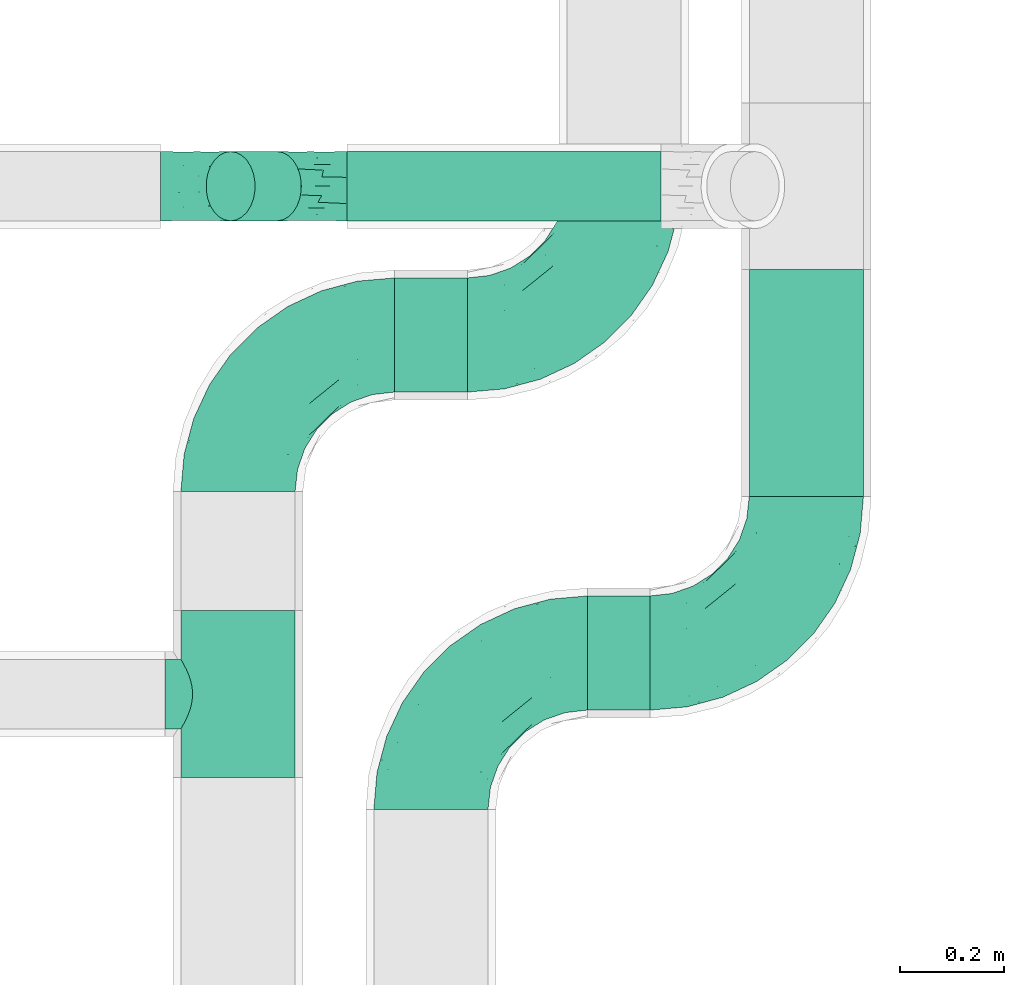
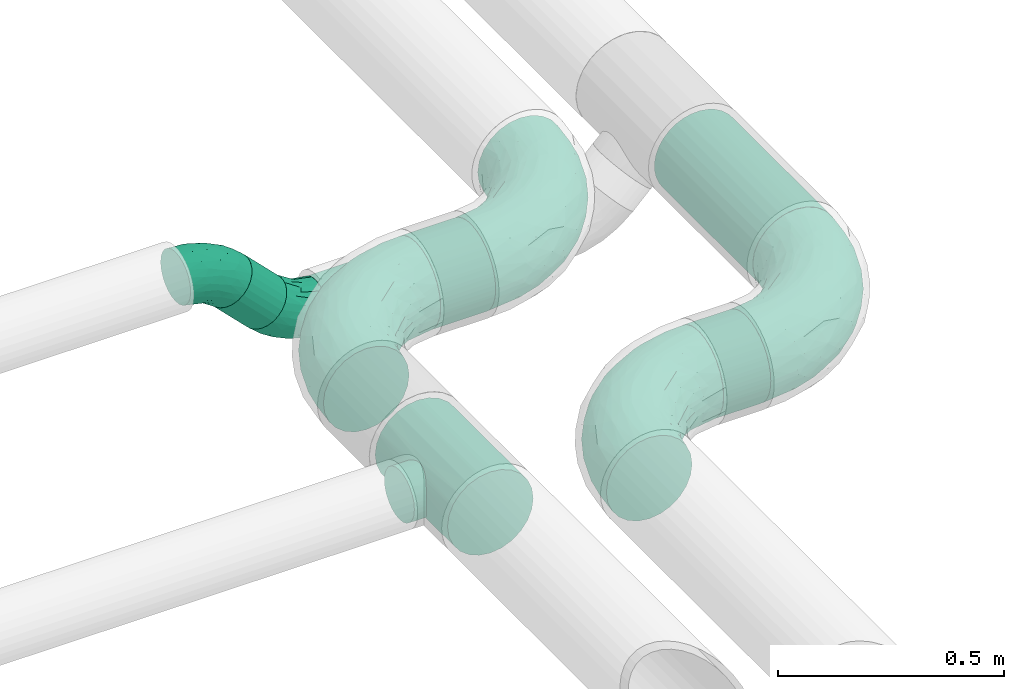
# One storey, part 73 of 93: 7 flow fittings, 5 flow segments.
"""IFC2X3 building model written with IfcOpenShell, lengths in millimetres."""

from ifc_helpers import new_model, entity, si_unit, converted_unit, derived_unit, direction, frame, origin, origin_2d_with_axis, place, context, subcontext, project, spatial, circle, extrude, faceted_brep, source, transform, mapped, material, type_object, type_shapes, element, save


model = new_model("IFC2X3")

# Units and contexts
model_context = context("Model", 3, precision=0.01, world=origin(), true_north=direction((6.12303176911189e-17, 1.0)))
body_context = subcontext(model_context, "Body", "Model", "MODEL_VIEW")
ifc_project = project(units=[si_unit("LENGTHUNIT", "METRE", prefix="MILLI"), si_unit("AREAUNIT", "SQUARE_METRE"), si_unit("VOLUMEUNIT", "CUBIC_METRE"), converted_unit("PLANEANGLEUNIT", "DEGREE", entity("IfcRatioMeasure", 0.0174532925199433), si_unit("PLANEANGLEUNIT", "RADIAN"), dimensions=[0, 0, 0, 0, 0, 0, 0]), si_unit("MASSUNIT", "GRAM", prefix="KILO"), derived_unit("MASSDENSITYUNIT", [(si_unit("MASSUNIT", "GRAM", prefix="KILO"), 1), (si_unit("LENGTHUNIT", "METRE"), -3)]), derived_unit("MOMENTOFINERTIAUNIT", [(si_unit("LENGTHUNIT", "METRE"), 4)]), si_unit("TIMEUNIT", "SECOND"), si_unit("FREQUENCYUNIT", "HERTZ"), si_unit("THERMODYNAMICTEMPERATUREUNIT", "DEGREE_CELSIUS"), derived_unit("THERMALTRANSMITTANCEUNIT", [(si_unit("MASSUNIT", "GRAM", prefix="KILO"), 1), (si_unit("THERMODYNAMICTEMPERATUREUNIT", "KELVIN"), -1), (si_unit("TIMEUNIT", "SECOND"), -3)]), derived_unit("VOLUMETRICFLOWRATEUNIT", [(si_unit("LENGTHUNIT", "METRE"), 3), (si_unit("TIMEUNIT", "SECOND"), -1)]), derived_unit("MASSFLOWRATEUNIT", [(si_unit("MASSUNIT", "GRAM", prefix="KILO"), 1), (si_unit("TIMEUNIT", "SECOND"), -1)]), derived_unit("ROTATIONALFREQUENCYUNIT", [(si_unit("TIMEUNIT", "SECOND"), -1)]), si_unit("ELECTRICCURRENTUNIT", "AMPERE"), si_unit("ELECTRICVOLTAGEUNIT", "VOLT"), si_unit("POWERUNIT", "WATT"), si_unit("FORCEUNIT", "NEWTON", prefix="KILO"), si_unit("ILLUMINANCEUNIT", "LUX"), si_unit("LUMINOUSFLUXUNIT", "LUMEN"), si_unit("LUMINOUSINTENSITYUNIT", "CANDELA"), derived_unit("USERDEFINED", [(si_unit("MASSUNIT", "GRAM", prefix="KILO"), -1), (si_unit("LENGTHUNIT", "METRE"), -2), (si_unit("TIMEUNIT", "SECOND"), 3), (si_unit("LUMINOUSFLUXUNIT", "LUMEN"), 1)]), derived_unit("LINEARVELOCITYUNIT", [(si_unit("LENGTHUNIT", "METRE"), 1), (si_unit("TIMEUNIT", "SECOND"), -1)]), si_unit("PRESSUREUNIT", "PASCAL"), derived_unit("USERDEFINED", [(si_unit("LENGTHUNIT", "METRE"), -2), (si_unit("MASSUNIT", "GRAM", prefix="KILO"), 1), (si_unit("TIMEUNIT", "SECOND"), -2)]), derived_unit("LINEARFORCEUNIT", [(si_unit("MASSUNIT", "GRAM", prefix="KILO"), 1), (si_unit("LENGTHUNIT", "METRE"), 1), (si_unit("TIMEUNIT", "SECOND"), -2), (si_unit("LENGTHUNIT", "METRE"), -1)]), derived_unit("PLANARFORCEUNIT", [(si_unit("MASSUNIT", "GRAM", prefix="KILO"), 1), (si_unit("LENGTHUNIT", "METRE"), 1), (si_unit("TIMEUNIT", "SECOND"), -2), (si_unit("LENGTHUNIT", "METRE"), -2)])], contexts=[model_context])

# Site, building, storey
site_placement = place(None, origin())
site = spatial("IfcSite", under=ifc_project, at=site_placement, CompositionType="ELEMENT")
building_placement = place(site_placement, origin())
building = spatial("IfcBuilding", under=site, at=building_placement, CompositionType="ELEMENT")
storey_placement = place(building_placement, frame((0.0, 0.0, -4200.0)))
storey = spatial("IfcBuildingStorey", under=building, at=storey_placement, CompositionType="ELEMENT", Elevation=-4200.0)

# Flow segments
pipe_segment_type = type_object("IfcPipeSegmentType", PredefinedType="NOTDEFINED")
flow_segment_1_placement = place(storey_placement, frame((31009.78, 8467.66, 2688.9)))
element("IfcFlowSegment", 1, at=flow_segment_1_placement, inside=storey, type_object=pipe_segment_type, context=body_context, shape_type="SweptSolid", body=[
    extrude(circle(Radius=109.5, at=origin_2d_with_axis()), frame((0.0, 111.1, 111.1), z_axis=(1.0, 0.0, 0.0), x_axis=(0.0, -1.0, 0.0)), (0.0, 0.0, 1.0), 120.218301649666),
])
flow_segment_2_placement = place(storey_placement, frame((30639.78, 9077.66, 2688.9)))
element("IfcFlowSegment", 2, at=flow_segment_2_placement, inside=storey, type_object=pipe_segment_type, context=body_context, shape_type="SweptSolid", body=[
    extrude(circle(Radius=109.5, at=origin_2d_with_axis()), frame((0.0, 111.1, 111.1), z_axis=(1.0, 0.0, 0.0), x_axis=(0.0, -1.0, 0.0)), (0.0, 0.0, 1.0), 140.218301649687),
])
flow_segment_3_placement = place(storey_placement, frame((31318.9, 8878.76, 2688.9)))
element("IfcFlowSegment", 3, at=flow_segment_3_placement, inside=storey, type_object=pipe_segment_type, context=body_context, shape_type="SweptSolid", body=[
    extrude(circle(Radius=109.5, at=origin_2d_with_axis()), frame((111.1, 0.0, 111.1), z_axis=(0.0, 1.0, 0.0), x_axis=(1.0, 0.0, 0.0)), (0.0, 0.0, 1.0), 435.378639737443),
])
flow_segment_4_placement = place(storey_placement, frame((30548.7, 9406.04, 2531.9)))
element("IfcFlowSegment", 4, at=flow_segment_4_placement, inside=storey, type_object=pipe_segment_type, context=body_context, shape_type="SweptSolid", body=[
    extrude(circle(Radius=66.5, at=origin_2d_with_axis()), frame((0.0, 68.1, 68.1), z_axis=(1.0, 0.0, 0.0), x_axis=(0.0, 1.0, 0.0)), (0.0, 0.0, 1.0), 602.598846298237),
])
flow_segment_5_placement = place(storey_placement, frame((30277.03, 9406.04, 2607.03)))
element("IfcFlowSegment", 5, at=flow_segment_5_placement, inside=storey, type_object=pipe_segment_type, context=body_context, shape_type="SweptSolid", body=[
    extrude(circle(Radius=66.5, at=origin_2d_with_axis()), frame((137.32, 68.1, 48.62), z_axis=(-0.707106781186466, 0.0, 0.70710678118663), x_axis=(0.0, 1.0, 0.0)), (0.0, 0.0, 1.0), 125.44155877284),
])

# Flow fittings
ifc_material = material()
pipe_fitting_type_1 = type_object("IfcPipeFittingType", Name="ADSK_2", PredefinedType="NOTDEFINED", material=ifc_material)
shared_shape_1 = source(origin(), body_context, "Body", "Brep", [
    faceted_brep([(-300.0, 54.75, -94.83), (-300.0, 28.34, -105.77), (-300.0, 0.0, -109.5), (-300.0, -28.34, -105.77), (-300.0, -54.75, -94.83), (-300.0, -77.43, -77.43), (-300.0, -94.83, -54.75), (-300.0, -105.77, -28.34), (-300.0, -109.5, 0.0), (-300.0, -105.77, 28.34), (-300.0, -94.83, 54.75), (-300.0, -77.43, 77.43), (-300.0, -54.75, 94.83), (-300.0, -28.34, 105.77), (-300.0, 0.0, 109.5), (-300.0, 28.34, 105.77), (-300.0, 54.75, 94.83), (-300.0, 77.43, 77.43), (-300.0, 94.83, 54.75), (-300.0, 105.77, 28.34), (-300.0, 109.5, 0.0), (-300.0, 105.77, -28.34), (-300.0, 94.83, -54.75), (-300.0, 77.43, -77.43), (0.0, 300.0, -109.5), (-28.34, 300.0, -105.77), (-54.75, 300.0, -94.83), (-77.43, 300.0, -77.43), (-94.83, 300.0, -54.75), (-105.77, 300.0, -28.34), (-109.5, 300.0, 0.0), (-105.77, 300.0, 28.34), (-94.83, 300.0, 54.75), (-77.43, 300.0, 77.43), (-54.75, 300.0, 94.83), (-28.34, 300.0, 105.77), (0.0, 300.0, 109.5), (28.34, 300.0, 105.77), (54.75, 300.0, 94.83), (77.43, 300.0, 77.43), (94.83, 300.0, 54.75), (105.77, 300.0, 28.34), (109.5, 300.0, 0.0), (105.77, 300.0, -28.34), (94.83, 300.0, -54.75), (77.43, 300.0, -77.43), (54.75, 300.0, -94.83), (28.34, 300.0, -105.77), (-136.7, 192.11, 33.4), (-108.06, 242.04, 45.72), (-115.25, 243.91, 23.63), (-228.89, -103.28, 0.0), (-205.72, -93.9, 30.98), (-223.48, -82.05, 62.89), (82.05, 223.48, 62.89), (-220.42, -37.16, 99.17), (-129.13, -11.54, 94.5), (-142.05, 16.57, 106.73), (-36.78, -13.7, 0.0), (-12.01, 12.01, 21.92), (-70.11, -34.19, 28.86), (-251.45, -65.77, 85.04), (25.82, 74.91, 52.65), (64.71, 143.75, 51.25), (23.5, 97.93, 73.21), (-132.85, -71.12, 23.16), (-159.94, -84.8, 0.0), (-95.25, -54.64, 0.0), (-96.13, 227.29, 70.78), (-125.84, 193.4, 53.02), (-74.91, -25.82, 52.65), (-17.67, 17.67, 46.21), (-143.75, -64.71, 51.25), (34.19, 70.11, 28.86), (-36.83, 151.15, 109.47), (-72.47, 101.01, 109.48), (-16.57, 142.05, 106.73), (-230.69, 46.79, 102.89), (-151.06, 181.23, 0.0), (-193.02, 137.32, 30.03), (-245.74, 114.87, 22.86), (-217.35, 128.37, 0.0), (-257.61, 114.28, 0.0), (-206.97, 23.39, 109.2), (-228.54, -10.67, 107.88), (-63.53, 63.53, 103.95), (-152.02, 152.02, 61.3), (-239.14, 108.86, 45.92), (-46.79, 230.69, 102.89), (-23.39, 206.97, 109.2), (-187.96, -54.73, 82.5), (13.7, 36.78, 0.0), (54.64, 95.25, 0.0), (-252.51, 68.8, 88.87), (10.67, 228.54, 107.88), (37.16, 220.42, 99.17), (-156.91, 87.58, 100.32), (-167.17, 59.01, 106.65), (103.28, 228.89, 0.0), (93.9, 205.72, 30.98), (84.8, 159.94, 0.0), (-63.56, 159.75, 106.59), (71.12, 132.85, 23.16), (-142.71, 44.43, 109.5), (63.87, 170.82, 67.63), (65.77, 251.45, 85.04), (54.73, 187.96, 82.5), (11.54, 129.13, 94.5), (-114.28, 257.61, 0.0), (-128.37, 217.35, 0.0), (-181.23, 151.06, 0.0), (-229.13, 95.58, 70.67), (-69.3, 249.25, 89.01), (-87.17, 189.36, 91.52), (-119.64, 123.85, 98.47), (-114.16, 102.69, 105.6), (-97.93, -23.5, 73.21), (-38.98, 38.98, 84.91), (-76.05, 27.59, 96.01), (-136.12, 132.19, 87.79), (-194.78, 84.82, 91.29), (-38.49, 15.54, 67.27), (-119.57, 181.27, 70.23), (-177.11, 114.75, 77.16), (-196.39, 119.69, 59.32), (-29.77, 73.43, 96.01), (-68.81, 187.42, 100.76), (-170.82, -63.87, 67.63), (-242.04, 108.06, -45.72), (-243.91, 115.25, -23.63), (-99.47, 217.21, -71.36), (-202.49, 24.61, -109.22), (-224.29, -9.94, -107.83), (-12.01, 12.01, -21.92), (34.19, 70.11, -28.86), (-243.92, 70.22, -89.23), (-224.05, 97.15, -70.96), (-70.11, -34.19, -28.86), (37.16, 220.42, -99.17), (-137.32, 193.02, -30.03), (-192.11, 136.7, -33.4), (-9.56, 157.76, -106.97), (9.82, 126.4, -94.6), (-26.99, 75.01, -95.39), (-108.86, 239.14, -45.92), (-121.71, 195.15, -57.54), (-193.4, 125.84, -53.02), (-168.29, 120.23, -77.72), (-131.44, 156.1, -76.48), (-114.09, 152.67, -89.71), (-58.82, 66.26, -103.46), (-72.9, 29.97, -95.91), (-148.76, 21.01, -108.12), (-235.23, -39.46, -99.56), (-209.2, -59.7, -83.37), (25.86, 75.0, -52.68), (-17.67, 17.67, -46.21), (-224.25, -82.18, -62.93), (-205.72, -93.9, -30.98), (-160.57, -20.91, -97.48), (-111.76, -26.64, -77.85), (71.12, 132.85, -23.16), (64.71, 143.75, -51.25), (93.9, 205.72, -30.98), (-132.85, -71.12, -23.16), (23.46, 97.98, -73.28), (-39.51, 14.6, -67.27), (-157.82, 65.68, -106.39), (-100.24, 111.65, -106.5), (-108.02, 70.62, -109.5), (-229.63, 47.01, -102.91), (-77.16, -26.73, -53.6), (-143.75, -64.71, -51.25), (-114.87, 245.74, -22.86), (-21.27, 215.47, -109.15), (-65.44, 173.68, -104.22), (-44.92, 240.82, -102.64), (-152.02, 152.02, -61.3), (11.39, 233.1, -107.93), (65.77, 251.45, -85.04), (-72.39, 233.4, -89.67), (-38.98, 38.98, -84.91), (-52.88, 131.78, -109.49), (-180.51, 91.33, -91.9), (82.05, 223.48, -62.89), (54.73, 187.96, -82.5), (-153.65, 46.01, -109.28), (-131.22, 111.56, -98.89), (-160.99, -57.92, -70.28), (63.87, 170.82, -67.63)], [[[0, 1, 2, 3, 4, 5, 6, 7, 8, 9, 10, 11, 12, 13, 14, 15, 16, 17, 18, 19, 20, 21, 22, 23]], [[24, 25, 26, 27, 28, 29, 30, 31, 32, 33, 34, 35, 36, 37, 38, 39, 40, 41, 42, 43, 44, 45, 46, 47]], [[48, 49, 50]], [[9, 51, 52]], [[10, 53, 11]], [[9, 52, 10]], [[39, 54, 40]], [[55, 56, 57]], [[9, 8, 51]], [[58, 59, 60]], [[11, 61, 12]], [[62, 63, 64]], [[65, 66, 67]], [[68, 49, 69]], [[58, 60, 67]], [[52, 51, 66]], [[55, 12, 61]], [[70, 60, 71]], [[65, 72, 52]], [[71, 73, 62]], [[74, 75, 76]], [[77, 16, 15]], [[49, 31, 50]], [[78, 79, 48]], [[80, 81, 82]], [[14, 83, 15]], [[14, 13, 84]], [[75, 85, 76]], [[48, 79, 86]], [[80, 87, 79]], [[84, 13, 55]], [[20, 19, 80]], [[20, 80, 82]], [[35, 88, 89]], [[53, 90, 61]], [[91, 92, 73]], [[16, 93, 17]], [[87, 19, 18]], [[58, 91, 59]], [[89, 36, 35]], [[94, 95, 37]], [[96, 77, 97]], [[98, 99, 100]], [[101, 75, 74]], [[99, 98, 41]], [[102, 73, 92]], [[83, 103, 97]], [[94, 76, 95]], [[63, 73, 102]], [[99, 40, 54]], [[104, 63, 54]], [[105, 39, 38]], [[52, 72, 53]], [[65, 67, 60]], [[40, 99, 41]], [[42, 41, 98]], [[35, 34, 88]], [[106, 95, 107]], [[50, 30, 108]], [[109, 48, 50]], [[77, 15, 83]], [[78, 110, 79]], [[111, 17, 93]], [[95, 106, 105]], [[68, 33, 32]], [[48, 109, 78]], [[12, 55, 13]], [[89, 88, 101]], [[110, 81, 79]], [[112, 68, 113]], [[17, 111, 18]], [[114, 96, 115]], [[116, 117, 118]], [[112, 34, 33]], [[107, 64, 106]], [[96, 119, 120]], [[95, 38, 37]], [[73, 71, 59]], [[92, 100, 102]], [[121, 117, 116]], [[49, 32, 31]], [[68, 69, 122]], [[123, 120, 119]], [[124, 79, 87]], [[56, 55, 90]], [[84, 57, 83]], [[116, 56, 90]], [[56, 116, 118]], [[37, 36, 94]], [[107, 95, 76]], [[125, 76, 85]], [[107, 125, 64]], [[112, 88, 34]], [[114, 101, 126]], [[97, 77, 83]], [[93, 77, 120]], [[52, 53, 10]], [[127, 53, 72]], [[54, 39, 105]], [[99, 54, 63]], [[100, 99, 102]], [[63, 102, 99]], [[72, 65, 60]], [[52, 66, 65]], [[127, 116, 90]], [[72, 60, 70]], [[64, 117, 121]], [[104, 64, 63]], [[57, 84, 55]], [[83, 14, 84]], [[36, 89, 94]], [[94, 89, 74]], [[18, 111, 87]], [[124, 87, 111]], [[73, 59, 91]], [[60, 59, 71]], [[126, 101, 88]], [[101, 115, 75]], [[115, 97, 103]], [[75, 103, 85]], [[118, 57, 56]], [[85, 118, 125]], [[69, 49, 48]], [[68, 32, 49]], [[83, 57, 103]], [[96, 97, 115]], [[85, 103, 57]], [[115, 103, 75]], [[30, 50, 31]], [[109, 50, 108]], [[68, 112, 33]], [[112, 113, 126]], [[96, 114, 119]], [[77, 96, 120]], [[122, 113, 68]], [[86, 124, 123]], [[101, 114, 115]], [[113, 119, 114]], [[77, 93, 16]], [[111, 93, 120]], [[121, 70, 71]], [[72, 70, 116]], [[63, 62, 73]], [[121, 62, 64]], [[87, 80, 19]], [[81, 80, 79]], [[53, 61, 11]], [[55, 61, 90]], [[95, 105, 38]], [[54, 105, 106]], [[116, 127, 72]], [[90, 53, 127]], [[54, 106, 104]], [[64, 104, 106]], [[70, 121, 116]], [[121, 71, 62]], [[123, 124, 111]], [[79, 124, 86]], [[120, 123, 111]], [[86, 123, 119]], [[112, 126, 88]], [[114, 126, 113]], [[94, 74, 76]], [[101, 74, 89]], [[125, 118, 117]], [[57, 118, 85]], [[64, 125, 117]], [[76, 125, 107]], [[48, 86, 69]], [[69, 86, 122]], [[86, 119, 122]], [[113, 122, 119]], [[128, 21, 129]], [[130, 28, 27]], [[2, 1, 131]], [[2, 131, 132]], [[91, 133, 134]], [[0, 23, 135]], [[136, 23, 22]], [[58, 67, 137]], [[82, 129, 20]], [[46, 138, 47]], [[139, 110, 78]], [[129, 81, 140]], [[141, 142, 143]], [[140, 81, 110]], [[144, 145, 139]], [[136, 128, 146]], [[147, 148, 149]], [[150, 151, 152]], [[153, 154, 4]], [[155, 134, 156]], [[157, 158, 6]], [[5, 157, 6]], [[159, 151, 160]], [[8, 7, 51]], [[154, 5, 4]], [[161, 162, 163]], [[164, 137, 67]], [[2, 132, 3]], [[165, 155, 166]], [[7, 158, 51]], [[66, 51, 158]], [[159, 160, 154]], [[167, 168, 169]], [[137, 156, 133]], [[1, 0, 170]], [[140, 128, 129]], [[78, 109, 139]], [[171, 137, 172]], [[156, 137, 171]], [[144, 29, 28]], [[30, 173, 108]], [[174, 175, 176]], [[173, 30, 29]], [[177, 140, 139]], [[157, 5, 154]], [[173, 144, 139]], [[174, 25, 24]], [[170, 131, 1]], [[178, 24, 47]], [[46, 179, 138]], [[167, 131, 170]], [[25, 176, 26]], [[173, 109, 108]], [[27, 180, 130]], [[165, 181, 143]], [[150, 182, 141]], [[92, 161, 100]], [[134, 92, 91]], [[183, 135, 136]], [[3, 153, 4]], [[98, 100, 163]], [[138, 142, 141]], [[91, 58, 133]], [[179, 46, 45]], [[44, 43, 163]], [[163, 162, 184]], [[42, 98, 43]], [[172, 137, 164]], [[6, 158, 7]], [[43, 98, 163]], [[161, 92, 134]], [[45, 44, 184]], [[180, 27, 26]], [[184, 185, 179]], [[130, 180, 149]], [[139, 140, 110]], [[67, 66, 164]], [[131, 152, 132]], [[178, 174, 24]], [[182, 169, 168]], [[128, 22, 21]], [[147, 183, 136]], [[142, 138, 185]], [[178, 138, 141]], [[165, 142, 185]], [[142, 165, 143]], [[150, 143, 151]], [[182, 150, 169]], [[135, 170, 0]], [[186, 167, 169]], [[131, 186, 152]], [[153, 132, 159]], [[176, 180, 26]], [[187, 175, 168]], [[175, 149, 180]], [[149, 183, 147]], [[171, 166, 156]], [[188, 154, 160]], [[163, 184, 44]], [[189, 184, 162]], [[66, 158, 164]], [[172, 164, 158]], [[162, 161, 134]], [[163, 100, 161]], [[188, 157, 154]], [[158, 157, 172]], [[189, 165, 185]], [[162, 134, 155]], [[28, 130, 144]], [[145, 144, 130]], [[137, 133, 58]], [[134, 133, 156]], [[170, 183, 167]], [[183, 149, 187]], [[150, 152, 169]], [[159, 132, 152]], [[138, 178, 47]], [[174, 178, 141]], [[167, 183, 187]], [[182, 175, 174]], [[175, 182, 168]], [[174, 141, 182]], [[146, 128, 140]], [[136, 22, 128]], [[132, 153, 3]], [[154, 153, 159]], [[174, 176, 25]], [[180, 176, 175]], [[136, 135, 23]], [[170, 135, 183]], [[20, 129, 21]], [[81, 129, 82]], [[188, 171, 172]], [[166, 160, 181]], [[160, 166, 171]], [[165, 166, 181]], [[166, 155, 156]], [[162, 155, 165]], [[144, 173, 29]], [[109, 173, 139]], [[184, 179, 45]], [[138, 179, 185]], [[146, 147, 136]], [[147, 177, 148]], [[145, 148, 177]], [[130, 149, 148]], [[151, 143, 181]], [[141, 143, 150]], [[160, 151, 181]], [[152, 151, 159]], [[171, 188, 160]], [[157, 188, 172]], [[165, 189, 162]], [[185, 184, 189]], [[148, 145, 130]], [[139, 145, 177]], [[152, 186, 169]], [[131, 167, 186]], [[175, 187, 149]], [[167, 187, 168]], [[140, 177, 146]], [[146, 177, 147]]]),
])
type_shapes(pipe_fitting_type_1, [shared_shape_1])
flow_fitting_1_placement = place(storey_placement, frame((30709.78, 8578.76, 2800.0), z_axis=(0.0, 0.0, 1.0), x_axis=(-1.0, 0.0, 0.0)))
element("IfcFlowFitting", 6, at=flow_fitting_1_placement, inside=storey, type_object=pipe_fitting_type_1, material=ifc_material, Name="ADSK_2", ObjectType="ADSK_2", context=body_context, shape_type="MappedRepresentation", body=[
    mapped(shared_shape_1, transform((0.0, 0.0, 0.0), scale=1.0)),
])
flow_fitting_2_placement = place(storey_placement, frame((31430.0, 8578.76, 2800.0)))
element("IfcFlowFitting", 7, at=flow_fitting_2_placement, inside=storey, type_object=pipe_fitting_type_1, material=ifc_material, Name="ADSK_2", ObjectType="ADSK_2", context=body_context, shape_type="MappedRepresentation", body=[
    mapped(shared_shape_1, transform((0.0, 0.0, 0.0), scale=1.0)),
])
flow_fitting_3_placement = place(storey_placement, frame((30339.78, 9188.76, 2800.0), z_axis=(0.0, 0.0, 1.0), x_axis=(-1.0, 0.0, 0.0)))
element("IfcFlowFitting", 8, at=flow_fitting_3_placement, inside=storey, type_object=pipe_fitting_type_1, material=ifc_material, Name="ADSK_2", ObjectType="ADSK_2", context=body_context, shape_type="MappedRepresentation", body=[
    mapped(shared_shape_1, transform((0.0, 0.0, 0.0), scale=1.0)),
])
flow_fitting_4_placement = place(storey_placement, frame((31080.0, 9188.76, 2800.0)))
element("IfcFlowFitting", 9, at=flow_fitting_4_placement, inside=storey, type_object=pipe_fitting_type_1, material=ifc_material, Name="ADSK_2", ObjectType="ADSK_2", context=body_context, shape_type="MappedRepresentation", body=[
    mapped(shared_shape_1, transform((0.0, 0.0, 0.0), scale=1.0)),
])
pipe_fitting_type_2 = type_object("IfcPipeFittingType", Name="ADSK_2", PredefinedType="NOTDEFINED", material=ifc_material)
shared_shape_2 = source(origin(), body_context, "Body", "Brep", [
    faceted_brep([(-160.0, 0.0, -109.5), (-160.0, -28.34, -105.77), (-160.0, -54.75, -94.83), (-160.0, -77.43, -77.43), (-160.0, -94.83, -54.75), (-160.0, -100.3, -41.55), (-160.0, -105.77, -28.34), (-160.0, -107.63, -14.17), (-160.0, -109.5, 0.0), (-160.0, -107.63, 14.17), (-160.0, -105.77, 28.34), (-160.0, -100.3, 41.55), (-160.0, -94.83, 54.75), (-160.0, -77.43, 77.43), (-160.0, -54.75, 94.83), (-160.0, -28.34, 105.77), (-160.0, 0.0, 109.5), (-160.0, 28.34, 105.77), (-160.0, 54.75, 94.83), (-160.0, 77.43, 77.43), (-160.0, 94.83, 54.75), (-160.0, 105.77, 28.34), (-160.0, 109.5, 0.0), (-160.0, 105.77, -28.34), (-160.0, 94.83, -54.75), (-160.0, 77.43, -77.43), (-160.0, 54.75, -94.83), (-160.0, 28.34, -105.77), (160.0, 28.34, -105.77), (160.0, 54.75, -94.83), (160.0, 77.43, -77.43), (160.0, 94.83, -54.75), (160.0, 105.77, -28.34), (160.0, 109.5, 0.0), (160.0, 105.77, 28.34), (160.0, 94.83, 54.75), (160.0, 77.43, 77.43), (160.0, 54.75, 94.83), (160.0, 28.34, 105.77), (160.0, 0.0, 109.5), (160.0, -28.34, 105.77), (160.0, -54.75, 94.83), (160.0, -77.43, 77.43), (160.0, -94.83, 54.75), (160.0, -100.3, 41.55), (160.0, -105.77, 28.34), (160.0, -107.63, 14.17), (160.0, -109.5, 0.0), (160.0, -107.63, -14.17), (160.0, -105.77, -28.34), (160.0, -100.3, -41.55), (160.0, -94.83, -54.75), (160.0, -77.43, -77.43), (160.0, -54.75, -94.83), (160.0, -28.34, -105.77), (160.0, 0.0, -109.5), (61.24, -106.39, 25.91), (65.16, -108.69, 13.3), (66.5, -109.5, 0.0), (55.06, -102.95, 37.29), (46.93, -98.84, 47.12), (37.11, -94.58, 55.18), (25.81, -90.74, 61.29), (-61.25, -106.39, 25.91), (-65.16, -108.69, 13.3), (-66.5, -109.5, 0.0), (-55.06, -102.96, 37.29), (-25.83, -90.75, 61.28), (-37.12, -94.58, 55.18), (-46.93, -98.85, 47.11), (-13.3, -88.01, 65.16), (-0.01, -86.99, 66.5), (13.28, -88.0, 65.16), (-0.01, -86.99, -66.5), (-13.3, -88.01, -65.16), (13.28, -88.0, -65.16), (46.93, -98.84, -47.12), (37.11, -94.58, -55.18), (-55.06, -102.96, -37.29), (25.81, -90.74, -61.29), (61.24, -106.39, -25.91), (65.16, -108.69, -13.3), (55.06, -102.95, -37.29), (-25.83, -90.75, -61.28), (-37.12, -94.58, -55.18), (-46.93, -98.85, -47.11), (-65.16, -108.69, -13.3), (-61.25, -106.39, -25.91), (0.0, -140.0, -66.5), (17.21, -140.0, -64.23), (33.25, -140.0, -57.59), (47.02, -140.0, -47.02), (57.59, -140.0, -33.25), (64.23, -140.0, -17.21), (66.5, -140.0, 0.0), (64.23, -140.0, 17.21), (57.59, -140.0, 33.25), (47.02, -140.0, 47.02), (33.25, -140.0, 57.59), (17.21, -140.0, 64.23), (0.0, -140.0, 66.5), (-17.21, -140.0, 64.23), (-33.25, -140.0, 57.59), (-47.02, -140.0, 47.02), (-57.59, -140.0, 33.25), (-64.23, -140.0, 17.21), (-66.5, -140.0, 0.0), (-64.23, -140.0, -17.21), (-57.59, -140.0, -33.25), (-47.02, -140.0, -47.02), (-33.25, -140.0, -57.59), (-17.21, -140.0, -64.23)], [[[0, 1, 2, 3, 4, 5, 6, 7, 8, 9, 10, 11, 12, 13, 14, 15, 16, 17, 18, 19, 20, 21, 22, 23, 24, 25, 26, 27]], [[28, 29, 30, 31, 32, 33, 34, 35, 36, 37, 38, 39, 40, 41, 42, 43, 44, 45, 46, 47, 48, 49, 50, 51, 52, 53, 54, 55]], [[45, 56, 46]], [[57, 58, 47]], [[57, 46, 56]], [[45, 59, 56]], [[44, 60, 59]], [[60, 44, 43]], [[61, 60, 43]], [[62, 61, 43]], [[63, 9, 64]], [[59, 45, 44]], [[63, 10, 9]], [[64, 8, 65]], [[8, 64, 9]], [[63, 66, 10]], [[12, 67, 13]], [[68, 67, 12]], [[69, 12, 11]], [[12, 69, 68]], [[66, 11, 10]], [[67, 70, 13]], [[57, 47, 46]], [[62, 43, 42]], [[15, 14, 41, 40]], [[71, 72, 42]], [[42, 72, 62]], [[41, 14, 13, 42]], [[16, 15, 40, 39]], [[20, 19, 36, 35]], [[21, 20, 35, 34]], [[18, 17, 38, 37]], [[19, 18, 37, 36]], [[38, 17, 16, 39]], [[22, 21, 34, 33]], [[13, 70, 71]], [[71, 42, 13]], [[69, 11, 66]], [[25, 24, 31, 30]], [[23, 22, 33, 32]], [[31, 24, 23, 32]], [[26, 25, 30, 29]], [[54, 53, 2, 1]], [[0, 27, 28, 55]], [[1, 0, 55, 54]], [[29, 28, 27, 26]], [[3, 2, 53, 52]], [[73, 74, 3]], [[3, 52, 73]], [[52, 75, 73]], [[51, 76, 77]], [[51, 50, 76]], [[78, 6, 5]], [[75, 52, 79]], [[77, 79, 51]], [[80, 48, 81]], [[79, 52, 51]], [[81, 48, 47]], [[81, 47, 58]], [[80, 82, 49]], [[80, 49, 48]], [[49, 82, 50]], [[83, 4, 3]], [[76, 50, 82]], [[84, 85, 4]], [[85, 78, 5]], [[84, 4, 83]], [[83, 3, 74]], [[86, 7, 87]], [[78, 87, 6]], [[7, 6, 87]], [[8, 86, 65]], [[5, 4, 85]], [[86, 8, 7]], [[88, 89, 90, 91, 92, 93, 94, 95, 96, 97, 98, 99, 100, 101, 102, 103, 104, 105, 106, 107, 108, 109, 110, 111]], [[65, 106, 64]], [[105, 64, 106]], [[66, 104, 103]], [[68, 103, 102]], [[105, 104, 63]], [[67, 102, 101]], [[63, 64, 105]], [[66, 103, 69]], [[104, 66, 63]], [[68, 102, 67]], [[70, 67, 101]], [[69, 103, 68]], [[100, 71, 70]], [[70, 101, 100]], [[99, 72, 100]], [[98, 62, 99]], [[96, 95, 56]], [[96, 59, 97]], [[61, 98, 97]], [[57, 95, 94]], [[62, 98, 61]], [[72, 99, 62]], [[97, 60, 61]], [[58, 57, 94]], [[56, 59, 96]], [[57, 56, 95]], [[97, 59, 60]], [[100, 72, 71]], [[93, 81, 94]], [[92, 80, 93]], [[92, 91, 82]], [[89, 88, 75]], [[91, 90, 77]], [[79, 90, 89]], [[81, 58, 94]], [[82, 80, 92]], [[81, 93, 80]], [[76, 91, 77]], [[79, 77, 90]], [[82, 91, 76]], [[79, 89, 75]], [[88, 73, 75]], [[110, 83, 111]], [[109, 84, 110]], [[86, 107, 106]], [[109, 108, 78]], [[107, 87, 108]], [[65, 86, 106]], [[74, 111, 83]], [[88, 74, 73]], [[110, 84, 83]], [[86, 87, 107]], [[84, 109, 85]], [[85, 109, 78]], [[108, 87, 78]], [[74, 88, 111]]]),
])
type_shapes(pipe_fitting_type_2, [shared_shape_2])
flow_fitting_5_placement = place(storey_placement, frame((30339.78, 8500.0, 2800.0), z_axis=(0.0, 0.0, 1.0), x_axis=(0.0, -1.0, 0.0)))
element("IfcFlowFitting", 10, at=flow_fitting_5_placement, inside=storey, type_object=pipe_fitting_type_2, material=ifc_material, Name="ADSK_2", ObjectType="ADSK_2", context=body_context, shape_type="MappedRepresentation", body=[
    mapped(shared_shape_2, transform((0.0, 0.0, 0.0), scale=1.0)),
])
pipe_fitting_type_3 = type_object("IfcPipeFittingType", Name="ADSK_2", PredefinedType="NOTDEFINED", material=ifc_material)
shared_shape_3 = source(origin(), body_context, "Body", "Brep", [
    faceted_brep([(-78.7, 33.25, -57.59), (-78.7, 17.21, -64.23), (-78.7, 0.0, -66.5), (-78.7, -17.21, -64.23), (-78.7, -33.25, -57.59), (-78.7, -47.02, -47.02), (-78.7, -57.59, -33.25), (-78.7, -64.23, -17.21), (-78.7, -66.5, 0.0), (-78.7, -64.23, 17.21), (-78.7, -57.59, 33.25), (-78.7, -47.02, 47.02), (-78.7, -33.25, 57.59), (-78.7, -17.21, 64.23), (-78.7, 0.0, 66.5), (-78.7, 17.21, 64.23), (-78.7, 33.25, 57.59), (-78.7, 47.02, 47.02), (-78.7, 57.59, 33.25), (-78.7, 64.23, 17.21), (-78.7, 66.5, 0.0), (-78.7, 64.23, -17.21), (-78.7, 57.59, -33.25), (-78.7, 47.02, -47.02), (55.65, 55.65, -66.5), (43.48, 67.82, -64.23), (32.14, 79.16, -57.59), (22.4, 88.9, -47.02), (14.93, 96.37, -33.25), (10.23, 101.07, -17.21), (8.63, 102.67, 0.0), (10.23, 101.07, 17.21), (14.93, 96.37, 33.25), (22.4, 88.9, 47.02), (32.14, 79.16, 57.59), (43.48, 67.82, 64.23), (55.65, 55.65, 66.5), (67.82, 43.48, 64.23), (79.16, 32.14, 57.59), (88.9, 22.4, 47.02), (96.37, 14.93, 33.25), (101.07, 10.23, 17.21), (102.67, 8.63, 0.0), (101.07, 10.23, -17.21), (96.37, 14.93, -33.25), (88.9, 22.4, -47.02), (79.16, 32.14, -57.59), (67.82, 43.48, -64.23), (-40.01, -57.38, 27.86), (-40.6, -61.75, 15.74), (-6.41, -52.87, 20.07), (-28.66, -61.57, 0.0), (44.74, 12.16, 61.0), (-23.71, -35.12, 51.77), (8.73, -21.07, 54.25), (-40.23, -23.04, 61.0), (-34.61, -49.5, 39.47), (-28.9, -3.87, 65.72), (-8.47, 20.45, 66.18), (-47.15, 10.46, 66.05), (-49.81, 55.22, 41.25), (-33.77, 66.88, 30.79), (-20.88, 50.42, 53.92), (7.4, 48.4, 61.91), (-34.71, 30.07, 61.97), (42.4, -35.06, 11.04), (19.46, -46.98, 0.0), (63.8, -23.27, 0.0), (-15.18, 67.35, 41.6), (14.82, -35.78, 38.27), (53.98, -24.32, 23.88), (-30.55, 73.76, 17.41), (-46.74, 70.71, 0.0), (59.47, -10.53, 39.47), (-16.95, 83.05, 0.0), (25.95, 40.74, 66.05), (41.59, -8.07, 51.77), (23.18, 17.7, 65.72), (74.36, -14.41, 12.26), (4.62, -11.15, 60.44), (-39.45, 28.99, -61.91), (-20.88, 50.42, -53.92), (3.28, 45.81, -61.97), (-23.41, 71.18, -30.79), (8.73, -21.07, -54.25), (4.62, -11.15, -60.44), (44.74, 12.16, -61.0), (-30.55, 73.76, -17.41), (-40.23, -23.04, -61.0), (-23.71, -35.12, -51.77), (-36.89, 58.36, -41.6), (-47.15, 10.46, -66.05), (-28.9, -3.87, -65.72), (-20.98, -55.37, -23.88), (-34.61, -49.5, -39.47), (68.86, -12.28, -27.86), (59.47, -10.53, -39.47), (-42.39, -62.77, -12.26), (41.59, -8.07, -51.77), (14.82, -35.78, -38.27), (41.92, -32.85, -20.07), (-5.19, -54.78, -11.04), (72.37, -14.95, -15.74), (-3.83, 74.27, -41.25), (25.95, 40.74, -66.05), (23.18, 17.7, -65.72), (-8.47, 20.45, -66.18)], [[[0, 1, 2, 3, 4, 5, 6, 7, 8, 9, 10, 11, 12, 13, 14, 15, 16, 17, 18, 19, 20, 21, 22, 23]], [[24, 25, 26, 27, 28, 29, 30, 31, 32, 33, 34, 35, 36, 37, 38, 39, 40, 41, 42, 43, 44, 45, 46, 47]], [[48, 49, 50]], [[49, 8, 51]], [[38, 37, 52]], [[12, 11, 53]], [[53, 54, 55]], [[56, 11, 10]], [[14, 13, 57]], [[13, 12, 55]], [[57, 58, 59]], [[60, 61, 18]], [[62, 63, 34]], [[18, 61, 19]], [[16, 15, 64]], [[17, 16, 62]], [[65, 66, 67]], [[60, 62, 68]], [[15, 14, 59]], [[34, 33, 62]], [[69, 50, 70]], [[19, 71, 72]], [[40, 39, 73]], [[72, 20, 19]], [[74, 71, 31]], [[50, 66, 65]], [[62, 16, 64]], [[56, 48, 69]], [[66, 50, 51]], [[36, 35, 75]], [[39, 38, 76]], [[76, 73, 39]], [[32, 31, 61]], [[75, 77, 36]], [[70, 41, 40]], [[77, 37, 36]], [[48, 56, 10]], [[70, 40, 73]], [[59, 64, 15]], [[76, 38, 52]], [[58, 75, 63]], [[42, 41, 78]], [[53, 56, 69]], [[17, 60, 18]], [[54, 79, 55]], [[72, 71, 74]], [[48, 9, 49]], [[30, 74, 31]], [[54, 69, 76]], [[31, 71, 61]], [[58, 57, 77]], [[32, 68, 33]], [[55, 57, 13]], [[68, 62, 33]], [[79, 52, 77]], [[35, 34, 63]], [[63, 62, 64]], [[73, 76, 69]], [[79, 77, 57]], [[78, 70, 65]], [[70, 73, 69]], [[56, 53, 11]], [[58, 63, 64]], [[53, 55, 12]], [[57, 55, 79]], [[77, 52, 37]], [[52, 79, 54]], [[57, 59, 14]], [[64, 59, 58]], [[63, 75, 35]], [[77, 75, 58]], [[62, 60, 17]], [[61, 60, 68]], [[32, 61, 68]], [[61, 71, 19]], [[9, 48, 10]], [[69, 48, 50]], [[8, 49, 9]], [[51, 50, 49]], [[78, 65, 67]], [[50, 65, 70]], [[42, 78, 67]], [[70, 78, 41]], [[69, 54, 53]], [[52, 54, 76]], [[1, 0, 80]], [[81, 82, 80]], [[28, 83, 29]], [[23, 81, 0]], [[20, 72, 21]], [[84, 85, 86]], [[21, 87, 83]], [[88, 89, 4]], [[81, 23, 90]], [[91, 92, 2]], [[26, 25, 82]], [[91, 2, 1]], [[93, 6, 94]], [[95, 96, 44]], [[8, 7, 97]], [[81, 80, 0]], [[93, 7, 6]], [[98, 96, 99]], [[88, 4, 3]], [[100, 66, 101]], [[6, 5, 94]], [[89, 5, 4]], [[2, 92, 3]], [[94, 89, 99]], [[93, 94, 99]], [[96, 98, 45]], [[87, 72, 74]], [[89, 94, 5]], [[74, 30, 29]], [[99, 100, 93]], [[72, 87, 21]], [[95, 43, 102]], [[103, 83, 28]], [[90, 103, 81]], [[26, 82, 81]], [[46, 45, 98]], [[104, 25, 24]], [[96, 95, 99]], [[22, 90, 23]], [[26, 81, 27]], [[84, 99, 89]], [[104, 105, 106]], [[84, 86, 98]], [[27, 103, 28]], [[24, 47, 105]], [[67, 66, 100]], [[44, 96, 45]], [[47, 46, 86]], [[100, 95, 102]], [[85, 92, 105]], [[67, 102, 42]], [[85, 88, 92]], [[106, 105, 92]], [[97, 93, 101]], [[22, 21, 83]], [[101, 66, 51]], [[104, 82, 25]], [[87, 74, 29]], [[106, 91, 80]], [[86, 105, 47]], [[106, 80, 82]], [[92, 88, 3]], [[88, 85, 84]], [[98, 86, 46]], [[105, 86, 85]], [[80, 91, 1]], [[92, 91, 106]], [[105, 104, 24]], [[82, 104, 106]], [[81, 103, 27]], [[83, 103, 90]], [[22, 83, 90]], [[83, 87, 29]], [[43, 95, 44]], [[99, 95, 100]], [[42, 102, 43]], [[67, 100, 102]], [[97, 101, 51]], [[100, 101, 93]], [[8, 97, 51]], [[93, 97, 7]], [[99, 84, 98]], [[88, 84, 89]]]),
])
type_shapes(pipe_fitting_type_3, [shared_shape_3])
for number, where, z_axis, x_axis, name in (
    (11, (30470.0, 9474.14, 2600.0), (0.0, 1.0, 0.0), (-1.0, 0.0, 0.0), "ADSK_2"),
    (12, (30270.0, 9474.14, 2800.0), (0.0, -1.0, 0.0), (-0.707106781186466, 0.0, 0.70710678118663), "ADSK_2"),
):
    element("IfcFlowFitting", number, at=place(storey_placement, frame(where, z_axis=z_axis, x_axis=x_axis)), inside=storey, type_object=pipe_fitting_type_3, material=ifc_material, Name=name, ObjectType="ADSK_2", context=body_context, shape_type="MappedRepresentation", body=[
        mapped(shared_shape_3, transform((0.0, 0.0, 0.0), scale=1.0)),
    ])

save(model, "model.ifc")
